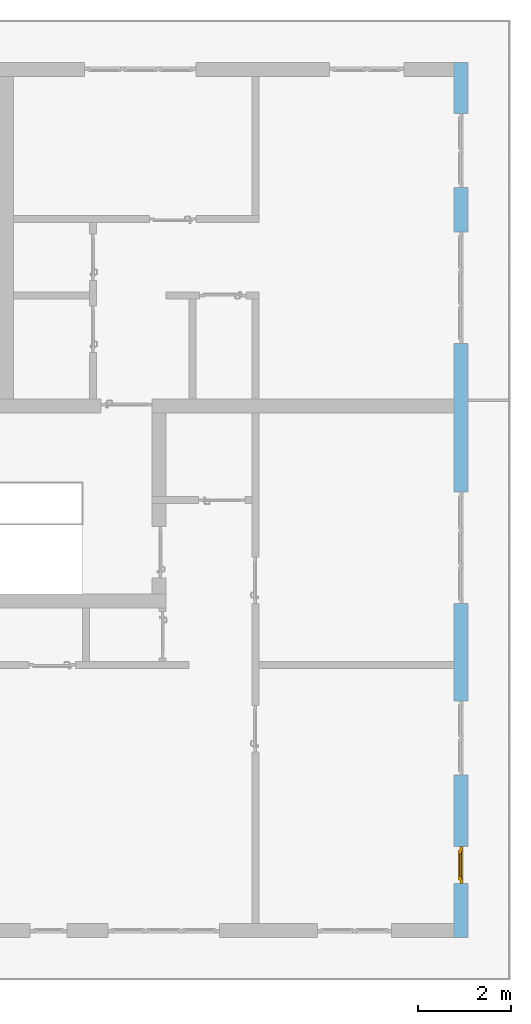
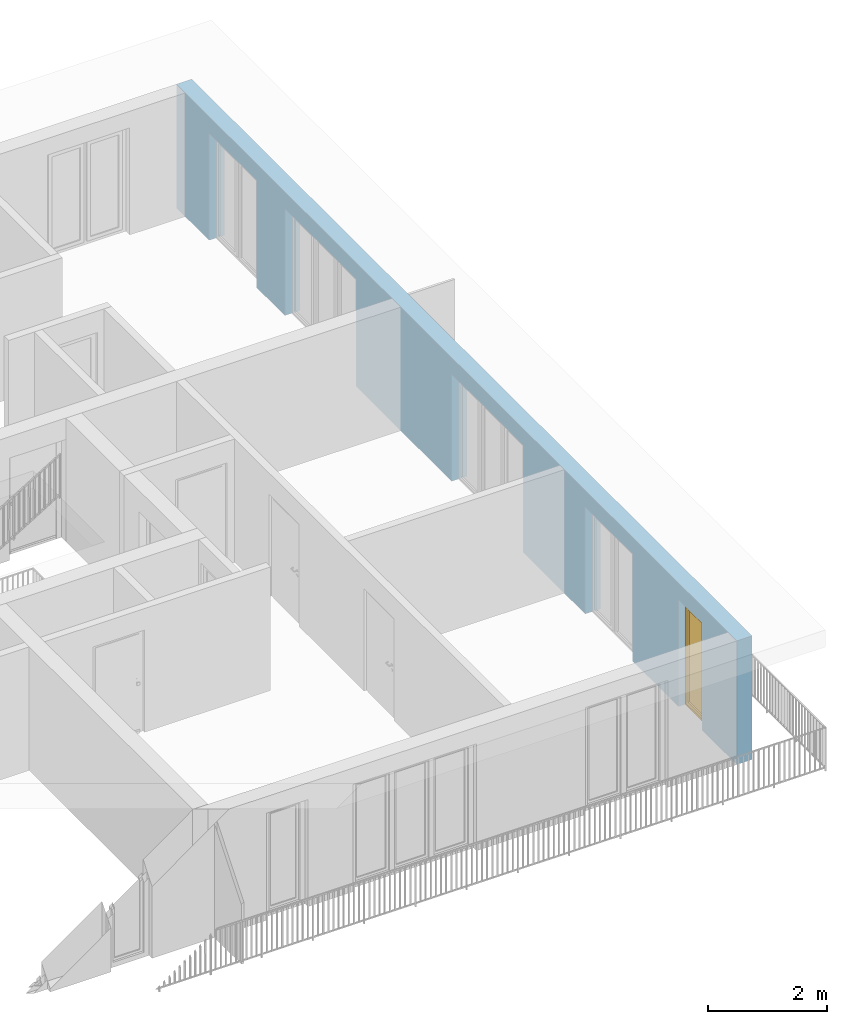
# One storey, part 22 of 54: 1 window, 5 openings, plus 1 element that does not belong to this part.
"""IFC4 building model written with IfcOpenShell, lengths in metres."""

from ifc_helpers import new_model, entity, si_unit, converted_unit, derived_unit, direction, frame, origin_with_axes, place, context, subcontext, project, spatial, polygons, source, transform, mapped, material, type_object, element, fill, save


model = new_model("IFC4")

# Units and contexts
model_context = context("Model", 3, precision=1e-05, world=origin_with_axes(), true_north=direction((0.0, 1.0)))
body_context = subcontext(model_context, "Body", "Model", "MODEL_VIEW")
ifc_project = project(units=[si_unit("LENGTHUNIT", "METRE"), si_unit("AREAUNIT", "SQUARE_METRE"), si_unit("VOLUMEUNIT", "CUBIC_METRE"), converted_unit("PLANEANGLEUNIT", "DEGREE", entity("IfcPlaneAngleMeasure", 0.0174532925199), si_unit("PLANEANGLEUNIT", "RADIAN"), dimensions=[0, 0, 0, 0, 0, 0, 0]), converted_unit("TIMEUNIT", "Year", entity("IfcTimeMeasure", 31556926.0), si_unit("TIMEUNIT", "SECOND"), dimensions=[0, 0, 1, 0, 0, 0, 0]), si_unit("MASSUNIT", "GRAM", prefix="KILO"), si_unit("THERMODYNAMICTEMPERATUREUNIT", "DEGREE_CELSIUS"), si_unit("LUMINOUSINTENSITYUNIT", "LUMEN"), si_unit("ENERGYUNIT", "JOULE", prefix="MEGA"), derived_unit("THERMALCONDUCTANCEUNIT", [(si_unit("POWERUNIT", "WATT"), 1), (si_unit("LENGTHUNIT", "METRE"), -1), (si_unit("THERMODYNAMICTEMPERATUREUNIT", "KELVIN"), -1)]), derived_unit("SPECIFICHEATCAPACITYUNIT", [(si_unit("ENERGYUNIT", "JOULE"), 1), (si_unit("MASSUNIT", "GRAM", prefix="KILO"), -1), (si_unit("THERMODYNAMICTEMPERATUREUNIT", "KELVIN"), -1)]), derived_unit("MASSDENSITYUNIT", [(si_unit("MASSUNIT", "GRAM", prefix="KILO"), 1), (si_unit("VOLUMEUNIT", "CUBIC_METRE"), -1)])], contexts=[model_context])

# Site, building, storey
site_placement = place(None, origin_with_axes())
site = spatial("IfcSite", under=ifc_project, at=site_placement, CompositionType="ELEMENT")
building_placement = place(site_placement, origin_with_axes())
building = spatial("IfcBuilding", under=site, at=building_placement, CompositionType="ELEMENT")
storey_placement = place(building_placement, frame((0.0, 0.0, 6.29), z_axis=(0.0, 0.0, 1.0), x_axis=(1.0, 0.0, 0.0)))
storey = spatial("IfcBuildingStorey", under=building, at=storey_placement, Name="2. Geschoss", CompositionType="ELEMENT", Elevation=6.29)

# Wall, openings, window
ifc_material = material()
wall_type = type_object("IfcWallType", Name="300", PredefinedType="NOTDEFINED")
wall_placement = place(storey_placement, frame((9.3378006196, -9.92881223104, 0.0), z_axis=(0.0, 0.0, 1.0), x_axis=(0.0, 1.0, 0.0)))
wall = element("IfcWall", 1, at=wall_placement, inside=storey, type_object=wall_type, material=ifc_material, Name="Wand-001", PredefinedType="NOTDEFINED", context=body_context, shape_type="Tessellation", body=[
    polygons([(1.16441876325, 0.1, 2.2), (1.96441876325, 0.1, 2.2), (1.96441876325, 0.0, 2.2), (1.16441876325, 0.0, 2.2), (1.16441876325, 0.3, 2.2), (1.96441876325, 0.3, 2.2), (1.96441876325, 0.1, 0.0), (1.96441876325, 0.0, 0.0), (18.85, 0.0, 2.54), (0.0, 0.0, 2.54), (0.0, 0.0, 0.0), (1.16441876325, 0.0, 0.0), (3.5, 0.0, 0.0), (3.5, 0.0, 2.2), (5.1, 0.0, 2.2), (5.1, 0.0, 0.0), (7.1921181063, 0.0, 0.0), (7.1921181063, 0.0, 2.2), (9.5921181063, 0.0, 2.2), (9.5921181063, 0.0, 0.0), (12.8, 0.0, 0.0), (12.8, 0.0, 2.2), (15.2, 0.0, 2.2), (15.2, 0.0, 0.0), (16.15, 0.0, 0.0), (16.15, 0.0, 2.2), (17.75, 0.0, 2.2), (17.75, 0.0, 0.0), (18.85, 0.0, 0.0), (1.16441876325, 0.1, 0.0), (1.16441876325, 0.3, 0.0), (0.0, 0.3, 0.0), (0.0, 0.3, 2.54), (18.85, 0.3, 2.54), (18.85, 0.3, 0.0), (17.75, 0.3, 0.0), (17.75, 0.3, 2.2), (16.15, 0.3, 2.2), (16.15, 0.3, 0.0), (15.2, 0.3, 0.0), (15.2, 0.3, 2.2), (12.8, 0.3, 2.2), (12.8, 0.3, 0.0), (9.5921181063, 0.3, 0.0), (9.5921181063, 0.3, 2.2), (7.1921181063, 0.3, 2.2), (7.1921181063, 0.3, 0.0), (5.1, 0.3, 0.0), (5.1, 0.3, 2.2), (3.5, 0.3, 2.2), (3.5, 0.3, 0.0), (1.96441876325, 0.3, 0.0), (3.5, 0.1, 0.0), (3.5, 0.1, 2.2), (5.1, 0.1, 2.2), (5.1, 0.1, 0.0), (7.1921181063, 0.1, 0.0), (7.1921181063, 0.1, 2.2), (9.5921181063, 0.1, 2.2), (9.5921181063, 0.1, 0.0), (12.8, 0.1, 0.0), (12.8, 0.1, 2.2), (15.2, 0.1, 2.2), (15.2, 0.1, 0.0), (16.15, 0.1, 0.0), (16.15, 0.1, 2.2), (17.75, 0.1, 2.2), (17.75, 0.1, 0.0)], [[[1, 2, 3, 4]], [[2, 1, 5, 6]], [[2, 7, 8, 3]], [[9, 10, 11, 12, 4, 3, 8, 13, 14, 15, 16, 17, 18, 19, 20, 21, 22, 23, 24, 25, 26, 27, 28, 29]], [[30, 1, 4, 12]], [[1, 30, 31, 5]], [[5, 31, 32, 33, 34, 35, 36, 37, 38, 39, 40, 41, 42, 43, 44, 45, 46, 47, 48, 49, 50, 51, 52, 6]], [[7, 2, 6, 52]], [[7, 52, 51, 53, 13, 8]], [[9, 34, 33, 10]], [[33, 32, 11, 10]], [[31, 30, 12, 11, 32]], [[14, 13, 53, 54]], [[15, 14, 54, 55]], [[16, 15, 55, 56]], [[56, 48, 47, 57, 17, 16]], [[57, 58, 18, 17]], [[58, 59, 19, 18]], [[59, 60, 20, 19]], [[60, 44, 43, 61, 21, 20]], [[22, 21, 61, 62]], [[23, 22, 62, 63]], [[24, 23, 63, 64]], [[64, 40, 39, 65, 25, 24]], [[65, 66, 26, 25]], [[66, 67, 27, 26]], [[67, 68, 28, 27]], [[36, 35, 29, 28, 68]], [[9, 29, 35, 34]], [[68, 67, 37, 36]], [[67, 66, 38, 37]], [[66, 65, 39, 38]], [[41, 40, 64, 63]], [[42, 41, 63, 62]], [[43, 42, 62, 61]], [[60, 59, 45, 44]], [[59, 58, 46, 45]], [[58, 57, 47, 46]], [[49, 48, 56, 55]], [[50, 49, 55, 54]], [[51, 50, 54, 53]]], closed=True),
])
opening_1_placement = place(wall_placement, frame((16.95, 0.0, 0.0), z_axis=(0.0, 0.0, 1.0), x_axis=(1.0, 0.0, 0.0)))
element("IfcOpeningElement", 2, at=opening_1_placement, cuts=wall, Name="Fenster-001", context=body_context, identifier="Reference", shape_type="Tessellation", body=[
    polygons([(0.8, 0.1, 0.0), (0.8, 0.1, 2.2), (0.8, -0.000999999999999, 2.2), (0.8, -0.000999999999999, 0.0), (0.8, 0.301, 0.0), (0.8, 0.301, 2.2), (-0.8, 0.1, 2.2), (-0.8, -0.000999999999999, 2.2), (-0.8, 0.301, 2.2), (-0.8, -0.000999999999999, 0.0), (-0.8, 0.1, 0.0), (-0.8, 0.301, 0.0)], [[[1, 2, 3, 4]], [[2, 1, 5, 6]], [[7, 8, 3, 2, 6, 9]], [[8, 10, 4, 3]], [[1, 4, 10, 11, 12, 5]], [[6, 5, 12, 9]], [[7, 11, 10, 8]], [[11, 7, 9, 12]]], closed=True),
])
opening_2_placement = place(wall_placement, frame((14.0, 0.0, 0.0), z_axis=(0.0, 0.0, 1.0), x_axis=(1.0, 0.0, 0.0)))
element("IfcOpeningElement", 3, at=opening_2_placement, cuts=wall, Name="Fenster-002", context=body_context, identifier="Reference", shape_type="Tessellation", body=[
    polygons([(1.2, 0.1, 0.0), (1.2, 0.1, 2.2), (1.2, -0.000999999999999, 2.2), (1.2, -0.000999999999999, 0.0), (1.2, 0.301, 0.0), (1.2, 0.301, 2.2), (-1.2, 0.1, 2.2), (-1.2, -0.000999999999999, 2.2), (-1.2, 0.301, 2.2), (-1.2, -0.000999999999999, 0.0), (-1.2, 0.1, 0.0), (-1.2, 0.301, 0.0)], [[[1, 2, 3, 4]], [[2, 1, 5, 6]], [[7, 8, 3, 2, 6, 9]], [[8, 10, 4, 3]], [[1, 4, 10, 11, 12, 5]], [[6, 5, 12, 9]], [[7, 11, 10, 8]], [[11, 7, 9, 12]]], closed=True),
])
opening_3_placement = place(wall_placement, frame((8.3921181063, 0.0, 0.0), z_axis=(0.0, 0.0, 1.0), x_axis=(1.0, 0.0, 0.0)))
element("IfcOpeningElement", 4, at=opening_3_placement, cuts=wall, Name="Fenster-002", context=body_context, identifier="Reference", shape_type="Tessellation", body=[
    polygons([(1.2, 0.1, 0.0), (1.2, 0.1, 2.2), (1.2, -0.000999999999999, 2.2), (1.2, -0.000999999999999, 0.0), (1.2, 0.301, 0.0), (1.2, 0.301, 2.2), (-1.2, 0.1, 2.2), (-1.2, -0.000999999999999, 2.2), (-1.2, 0.301, 2.2), (-1.2, -0.000999999999999, 0.0), (-1.2, 0.1, 0.0), (-1.2, 0.301, 0.0)], [[[1, 2, 3, 4]], [[2, 1, 5, 6]], [[7, 8, 3, 2, 6, 9]], [[8, 10, 4, 3]], [[1, 4, 10, 11, 12, 5]], [[6, 5, 12, 9]], [[7, 11, 10, 8]], [[11, 7, 9, 12]]], closed=True),
])
opening_4_placement = place(wall_placement, frame((4.3, 0.0, 0.0), z_axis=(0.0, 0.0, 1.0), x_axis=(1.0, 0.0, 0.0)))
element("IfcOpeningElement", 5, at=opening_4_placement, cuts=wall, Name="Fenster-001", context=body_context, identifier="Reference", shape_type="Tessellation", body=[
    polygons([(0.8, 0.1, 0.0), (0.8, 0.1, 2.2), (0.8, -0.000999999999999, 2.2), (0.8, -0.000999999999999, 0.0), (0.8, 0.301, 0.0), (0.8, 0.301, 2.2), (-0.8, 0.1, 2.2), (-0.8, -0.000999999999999, 2.2), (-0.8, 0.301, 2.2), (-0.8, -0.000999999999999, 0.0), (-0.8, 0.1, 0.0), (-0.8, 0.301, 0.0)], [[[1, 2, 3, 4]], [[2, 1, 5, 6]], [[7, 8, 3, 2, 6, 9]], [[8, 10, 4, 3]], [[1, 4, 10, 11, 12, 5]], [[6, 5, 12, 9]], [[7, 11, 10, 8]], [[11, 7, 9, 12]]], closed=True),
])
opening_5_placement = place(wall_placement, frame((1.56441876325, 0.0, 0.0), z_axis=(0.0, 0.0, 1.0), x_axis=(1.0, 0.0, 0.0)))
opening_5 = element("IfcOpeningElement", 6, at=opening_5_placement, cuts=wall, Name="Fenster-003", context=body_context, identifier="Reference", shape_type="Tessellation", body=[
    polygons([(0.4, 0.1, 0.0), (0.4, 0.1, 2.2), (0.4, -0.000999999999999, 2.2), (0.4, -0.000999999999999, 0.0), (0.4, 0.301, 0.0), (0.4, 0.301, 2.2), (-0.4, 0.1, 2.2), (-0.4, -0.000999999999999, 2.2), (-0.4, 0.301, 2.2), (-0.4, -0.000999999999999, 0.0), (-0.4, 0.1, 0.0), (-0.4, 0.301, 0.0)], [[[1, 2, 3, 4]], [[2, 1, 5, 6]], [[7, 8, 3, 2, 6, 9]], [[8, 10, 4, 3]], [[1, 4, 10, 11, 12, 5]], [[6, 5, 12, 9]], [[7, 11, 10, 8]], [[11, 7, 9, 12]]], closed=True),
])
window_type = type_object("IfcWindowType", Name="1-26", PartitioningType="SINGLE_PANEL", PredefinedType="WINDOW")
shared_shape = source(origin_with_axes(), body_context, "Body", "Tessellation", [
    polygons([(0.4, -0.07, 0.0), (0.3, -0.07, 0.1), (0.3, 0.0, 0.1), (0.4, 0.0, 0.0), (0.4, -0.07, 2.2), (0.3, -0.07, 2.1), (0.3, 0.0, 2.1), (0.4, 0.0, 2.2)], [[[1, 2, 3, 4]], [[1, 5, 6, 2]], [[2, 6, 7, 3]], [[4, 3, 7, 8]], [[5, 1, 4, 8]], [[6, 5, 8, 7]]], closed=True),
    polygons([(-0.4, -0.07, 0.0), (-0.4, -0.07, 2.2), (-0.4, 0.0, 2.2), (-0.4, 0.0, 0.0), (-0.3, -0.07, 0.1), (-0.3, -0.07, 2.1), (-0.3, 0.0, 2.1), (-0.3, 0.0, 0.1)], [[[1, 2, 3, 4]], [[1, 5, 6, 2]], [[2, 6, 7, 3]], [[4, 3, 7, 8]], [[5, 1, 4, 8]], [[6, 5, 8, 7]]], closed=True),
    polygons([(0.4, -0.07, 0.0), (-0.4, -0.07, 0.0), (-0.4, 0.0, 0.0), (0.4, 0.0, 0.0), (0.3, -0.07, 0.1), (0.0, -0.07, 0.1), (-0.3, -0.07, 0.1), (-0.3, 0.0, 0.1), (0.0, 0.0, 0.1), (0.3, 0.0, 0.1)], [[[1, 2, 3, 4]], [[1, 5, 6, 7, 2]], [[2, 7, 8, 3]], [[4, 3, 8, 9, 10]], [[5, 1, 4, 10]], [[6, 5, 10, 9]], [[7, 6, 9, 8]]], closed=True),
    polygons([(0.4, -0.07, 2.2), (0.3, -0.07, 2.1), (0.3, 0.0, 2.1), (0.4, 0.0, 2.2), (-0.4, -0.07, 2.2), (-0.3, -0.07, 2.1), (0.0, -0.07, 2.1), (0.0, 0.0, 2.1), (-0.3, 0.0, 2.1), (-0.4, 0.0, 2.2)], [[[1, 2, 3, 4]], [[1, 5, 6, 7, 2]], [[2, 7, 8, 3]], [[4, 3, 8, 9, 10]], [[5, 1, 4, 10]], [[6, 5, 10, 9]], [[7, 6, 9, 8]]], closed=True),
    polygons([(0.32, 0.0, 0.08), (0.25, 0.0, 0.15), (0.25, 0.03, 0.15), (0.32, 0.03, 0.08), (0.32, 0.0, 2.12), (0.25, 0.0, 2.05), (0.25, 0.03, 2.05), (0.32, 0.03, 2.12)], [[[1, 2, 3, 4]], [[1, 5, 6, 2]], [[2, 6, 7, 3]], [[4, 3, 7, 8]], [[5, 1, 4, 8]], [[6, 5, 8, 7]]], closed=True),
    polygons([(-0.32, 0.0, 0.08), (-0.32, 0.03, 0.08), (-0.25, 0.03, 0.15), (-0.25, 0.0, 0.15), (-0.32, 0.0, 2.12), (-0.32, 0.03, 2.12), (-0.25, 0.03, 2.05), (-0.25, 0.0, 2.05)], [[[1, 2, 3, 4]], [[5, 6, 2, 1]], [[2, 6, 7, 3]], [[4, 3, 7, 8]], [[1, 4, 8, 5]], [[8, 7, 6, 5]]], closed=True),
    polygons([(0.32, 0.0, 0.08), (-0.32, 0.0, 0.08), (-0.32, 0.03, 0.08), (0.32, 0.03, 0.08), (0.25, 0.0, 0.15), (-0.25, 0.0, 0.15), (-0.25, 0.03, 0.15), (0.25, 0.03, 0.15)], [[[1, 2, 3, 4]], [[1, 5, 6, 2]], [[2, 6, 7, 3]], [[4, 3, 7, 8]], [[5, 1, 4, 8]], [[6, 5, 8, 7]]], closed=True),
    polygons([(0.32, 0.0, 2.12), (0.32, 0.03, 2.12), (-0.32, 0.03, 2.12), (-0.32, 0.0, 2.12), (0.25, 0.0, 2.05), (0.25, 0.03, 2.05), (-0.25, 0.03, 2.05), (-0.25, 0.0, 2.05)], [[[1, 2, 3, 4]], [[5, 6, 2, 1]], [[2, 6, 7, 3]], [[4, 3, 7, 8]], [[1, 4, 8, 5]], [[8, 7, 6, 5]]], closed=True),
    polygons([(0.3, -0.03, 0.1), (0.25, -0.03, 0.15), (0.25, 0.0, 0.15), (0.3, 0.0, 0.1), (0.3, -0.03, 2.1), (0.25, -0.03, 2.05), (0.25, 0.0, 2.05), (0.3, 0.0, 2.1)], [[[1, 2, 3, 4]], [[1, 5, 6, 2]], [[2, 6, 7, 3]], [[4, 3, 7, 8]], [[5, 1, 4, 8]], [[6, 5, 8, 7]]], closed=True),
    polygons([(-0.3, -0.03, 0.1), (-0.3, 0.0, 0.1), (-0.25, 0.0, 0.15), (-0.25, -0.03, 0.15), (-0.3, -0.03, 2.1), (-0.3, 0.0, 2.1), (-0.25, 0.0, 2.05), (-0.25, -0.03, 2.05)], [[[1, 2, 3, 4]], [[5, 6, 2, 1]], [[2, 6, 7, 3]], [[4, 3, 7, 8]], [[1, 4, 8, 5]], [[8, 7, 6, 5]]], closed=True),
    polygons([(0.3, -0.03, 0.1), (-0.3, -0.03, 0.1), (-0.3, 0.0, 0.1), (0.3, 0.0, 0.1), (0.25, -0.03, 0.15), (-0.25, -0.03, 0.15), (-0.25, 0.0, 0.15), (0.25, 0.0, 0.15)], [[[1, 2, 3, 4]], [[1, 5, 6, 2]], [[2, 6, 7, 3]], [[4, 3, 7, 8]], [[5, 1, 4, 8]], [[6, 5, 8, 7]]], closed=True),
    polygons([(0.3, -0.03, 2.1), (0.3, 0.0, 2.1), (-0.3, 0.0, 2.1), (-0.3, -0.03, 2.1), (0.25, -0.03, 2.05), (0.25, 0.0, 2.05), (-0.25, 0.0, 2.05), (-0.25, -0.03, 2.05)], [[[1, 2, 3, 4]], [[5, 6, 2, 1]], [[2, 6, 7, 3]], [[4, 3, 7, 8]], [[1, 4, 8, 5]], [[8, 7, 6, 5]]], closed=True),
    polygons([(0.25, -0.005, 0.15), (-0.25, -0.005, 0.15), (-0.25, 0.005, 0.15), (0.25, 0.005, 0.15), (0.25, -0.005, 2.05), (-0.25, -0.005, 2.05), (-0.25, 0.005, 2.05), (0.25, 0.005, 2.05)], [[[1, 2, 3, 4]], [[1, 5, 6, 2]], [[2, 6, 7, 3]], [[4, 3, 7, 8]], [[5, 1, 4, 8]], [[6, 5, 8, 7]]], closed=True),
])
window_placement = place(opening_5_placement, frame((-0.4, 0.0, 0.0), z_axis=(0.0, 0.0, 1.0), x_axis=(1.0, 0.0, 0.0)))
window = element("IfcWindow", 7, at=window_placement, inside=storey, type_object=window_type, Name="Fenster-003", OverallHeight=2.2, OverallWidth=0.8, PredefinedType="WINDOW", context=body_context, shape_type="MappedRepresentation", body=[
    mapped(shared_shape, transform((0.4, 0.17, 0.0))),
])
fill(opening_5, window)

save(model, "model.ifc")
